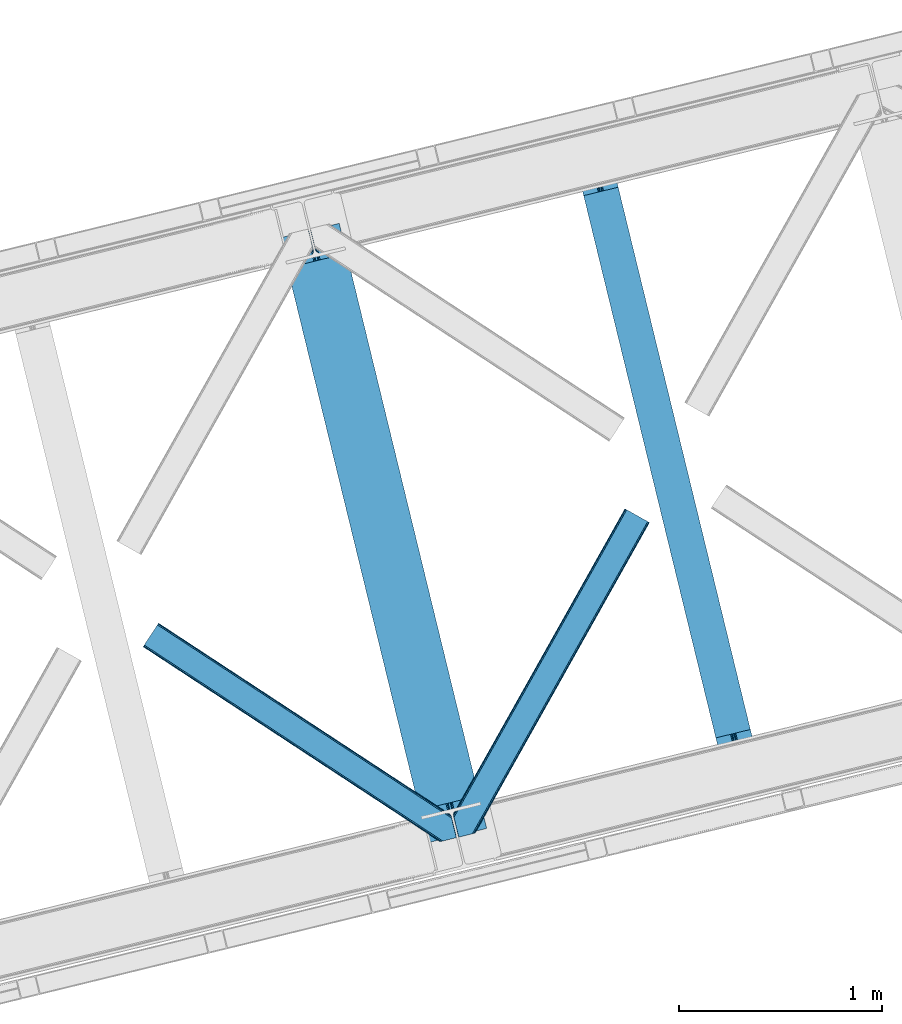
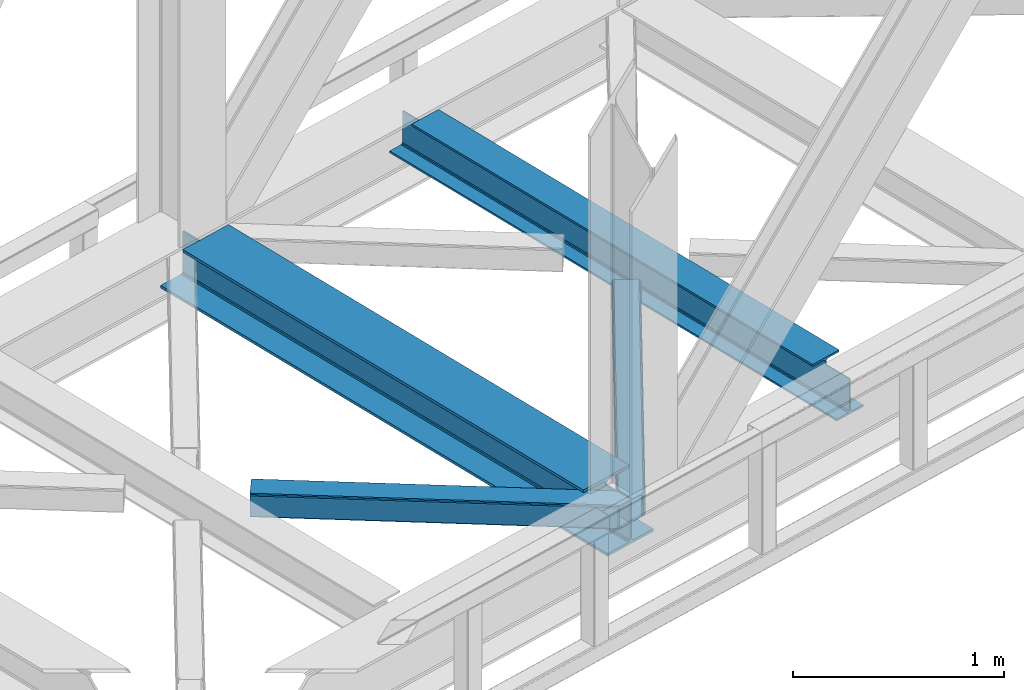
# One storey, part 79 of 92: 2 beams, 2 members.
"""IFC4 building model written with IfcOpenShell, lengths in millimetres."""

from ifc_helpers import new_model, entity, si_unit, converted_unit, derived_unit, direction, frame, origin, place, context, subcontext, project, spatial, triangles, polygons, material, type_object, element, save


model = new_model("IFC4")

# Units and contexts
model_context = context("Model", 3, precision=0.01, world=origin(), true_north=direction((6.12303176911189e-17, 1.0)))
plan_context = context("Plan", 3, precision=0.01, world=origin(), true_north=direction((6.12303176911189e-17, 1.0)))
body_context = subcontext(model_context, "Body", "Model", "MODEL_VIEW")
ifc_project = project(units=[si_unit("LENGTHUNIT", "METRE", prefix="MILLI"), si_unit("AREAUNIT", "SQUARE_METRE"), si_unit("VOLUMEUNIT", "CUBIC_METRE"), converted_unit("PLANEANGLEUNIT", "DEGREE", entity("IfcRatioMeasure", 0.0174532925199433), si_unit("PLANEANGLEUNIT", "RADIAN"), dimensions=[0, 0, 0, 0, 0, 0, 0]), si_unit("MASSUNIT", "GRAM", prefix="KILO"), derived_unit("MASSDENSITYUNIT", [(si_unit("MASSUNIT", "GRAM", prefix="KILO"), 1), (si_unit("LENGTHUNIT", "METRE"), -3)]), derived_unit("MOMENTOFINERTIAUNIT", [(si_unit("LENGTHUNIT", "METRE"), 4)]), si_unit("TIMEUNIT", "SECOND"), si_unit("FREQUENCYUNIT", "HERTZ"), si_unit("THERMODYNAMICTEMPERATUREUNIT", "DEGREE_CELSIUS"), derived_unit("THERMALTRANSMITTANCEUNIT", [(si_unit("MASSUNIT", "GRAM", prefix="KILO"), 1), (si_unit("THERMODYNAMICTEMPERATUREUNIT", "KELVIN"), -1), (si_unit("TIMEUNIT", "SECOND"), -3)]), derived_unit("VOLUMETRICFLOWRATEUNIT", [(si_unit("LENGTHUNIT", "METRE"), 3), (si_unit("TIMEUNIT", "SECOND"), -1)]), derived_unit("MASSFLOWRATEUNIT", [(si_unit("MASSUNIT", "GRAM", prefix="KILO"), 1), (si_unit("TIMEUNIT", "SECOND"), -1)]), derived_unit("ROTATIONALFREQUENCYUNIT", [(si_unit("TIMEUNIT", "SECOND"), -1)]), si_unit("ELECTRICCURRENTUNIT", "AMPERE"), si_unit("ELECTRICVOLTAGEUNIT", "VOLT"), si_unit("POWERUNIT", "WATT"), si_unit("FORCEUNIT", "NEWTON", prefix="KILO"), si_unit("ILLUMINANCEUNIT", "LUX"), si_unit("LUMINOUSFLUXUNIT", "LUMEN"), si_unit("LUMINOUSINTENSITYUNIT", "CANDELA"), derived_unit("USERDEFINED", [(si_unit("MASSUNIT", "GRAM", prefix="KILO"), -1), (si_unit("LENGTHUNIT", "METRE"), -2), (si_unit("TIMEUNIT", "SECOND"), 3), (si_unit("LUMINOUSFLUXUNIT", "LUMEN"), 1)]), derived_unit("LINEARVELOCITYUNIT", [(si_unit("LENGTHUNIT", "METRE"), 1), (si_unit("TIMEUNIT", "SECOND"), -1)]), si_unit("PRESSUREUNIT", "PASCAL"), derived_unit("USERDEFINED", [(si_unit("LENGTHUNIT", "METRE"), -2), (si_unit("MASSUNIT", "GRAM", prefix="KILO"), 1), (si_unit("TIMEUNIT", "SECOND"), -2)]), derived_unit("LINEARFORCEUNIT", [(si_unit("MASSUNIT", "GRAM", prefix="KILO"), 1), (si_unit("LENGTHUNIT", "METRE"), 1), (si_unit("TIMEUNIT", "SECOND"), -2), (si_unit("LENGTHUNIT", "METRE"), -1)]), derived_unit("PLANARFORCEUNIT", [(si_unit("MASSUNIT", "GRAM", prefix="KILO"), 1), (si_unit("LENGTHUNIT", "METRE"), 1), (si_unit("TIMEUNIT", "SECOND"), -2), (si_unit("LENGTHUNIT", "METRE"), -2)])], contexts=[model_context, plan_context])

# Site, building, storey
site_placement = place(None, origin())
site = spatial("IfcSite", under=ifc_project, at=site_placement, CompositionType="ELEMENT")
building_placement = place(site_placement, origin())
building = spatial("IfcBuilding", under=site, at=building_placement, CompositionType="ELEMENT")
storey_placement = place(building_placement, frame((0.0, 0.0, 15900.0)))
storey = spatial("IfcBuildingStorey", under=building, at=storey_placement, Name="05", CompositionType="ELEMENT", Elevation=15900.0)

# Beams
ifc_material = material(Name="Metal painted (White)")
beam_type = type_object("IfcBeamType", PredefinedType="BEAM")
beam_1_placement = place(storey_placement, frame((-9086.33, 15580.04, 3385.0)))
element("IfcBeam", 1, at=beam_1_placement, inside=storey, type_object=beam_type, material=ifc_material, ObjectType="Steel Beam", PredefinedType="BEAM", context=body_context, shape_type="Tessellation", body=[
    polygons([(1018.1664837833, 71.0478278971021, 15.4999999999986), (1018.1664837833, 71.0478278971021, 0.0), (291.465617442452, 3052.25531830421, 0.0), (291.465617442452, 3052.25531830421, 15.4999999999986), (894.779372399334, 40.9709140873313, 15.4999999999986), (168.078506058486, 3022.17840449444, 15.4999999999986), (888.08702862538, 39.3395844888265, 16.8701684147963), (161.386162284532, 3020.54707489594, 16.8701684147963), (882.413533524765, 37.956610033654, 20.7720779386456), (155.712667183913, 3019.16410044077, 20.7720779386456), (878.622625296187, 37.0325360459184, 26.6116982174294), (151.921758955338, 3018.24002645303, 26.6116982174294), (877.291435352789, 36.7080444135029, 33.500000000001), (150.590569011938, 3017.91553482062, 33.500000000001), (140.875048430526, 3015.54727389071, 33.500000000001), (140.875048430525, 3015.54727389071, 259.000000000002), (150.590569011936, 3017.91553482062, 259.000000000002), (0.0, 2981.20749040711, 0.0), (3.24860138789518e-12, 2981.20749040711, 15.4999999999986), (123.387111383965, 3011.28440421689, 15.4999999999986), (130.079455157938, 3012.91573381539, 16.8701684147963), (135.752950258552, 3014.29870827056, 20.7720779386369), (139.543858487129, 3015.2227822583, 26.6116982174294), (877.291435352786, 36.7080444135029, 259.000000000002), (867.575914771374, 34.3397834836014, 259.000000000002), (867.575914771377, 34.3397834836014, 33.500000000001), (866.24472482798, 34.0152918511859, 26.6116982174294), (862.453816599403, 33.0912178634502, 20.7720779386369), (856.780321498787, 31.70824340828, 16.8701684147963), (850.087977724816, 30.0769138097708, 15.4999999999986), (726.700866340855, 0.0, 15.4999999999986), (726.700866340851, 0.0, 0.0), (838.124523615913, 197.385937999181, 259.069791973884), (186.469722099971, 2870.72539801219, 259.000000000002), (186.693115201823, 2869.80895360721, 259.61730333112), (186.70550404545, 2869.75812937344, 266.500003008253), (837.979344808147, 197.981416001704, 266.500002998871), (837.979694928899, 197.979979696973, 260.000004007589), (828.499586345882, 194.645865944434, 259.006343171919), (828.27621632612, 195.562317481914, 259.61730333112), (828.263827482491, 195.613141715687, 266.500003008253), (176.989986719794, 2867.38985508742, 266.500002998871), (176.989636599042, 2867.39129139215, 260.000004007589), (176.844830940702, 2867.98534020594, 259.07612046749), (176.75420151856, 2868.35713708228, 259.000000000002), (839.310832678078, 198.30468544639, 273.388305639783), (843.101109266769, 199.231350618303, 279.227924098777), (848.774180214308, 200.616065081981, 283.129832400619), (855.466371895439, 202.248018612794, 284.500000377228), (978.853400583268, 232.325271667905, 284.500000138971), (978.851730776625, 232.332121736637, 299.999995328161), (687.386308679347, 161.283492472596, 299.999995890962), (687.387978486002, 161.276642403863, 284.500000701776), (810.775007173842, 191.353895458974, 284.500000463519), (817.467494070002, 192.984637925557, 283.129832461069), (823.141405718754, 194.365903570079, 279.227924137322), (826.93294050575, 195.287407219375, 273.388305663684), (175.658498849867, 2867.06658564273, 273.388305639783), (171.868222261169, 2866.13992047082, 279.227924098781), (166.195151313643, 2864.75520600715, 283.129832400619), (159.502959632494, 2863.12325247633, 284.500000377228), (36.1159309446587, 2833.04599942122, 284.500000138971), (36.117600751305, 2833.03914935249, 299.999995328161), (327.583022848581, 2904.08777861653, 299.999995890962), (327.581353041927, 2904.09462868526, 284.500000701776), (204.194324354092, 2874.01737563015, 284.500000463519), (197.50183745795, 2872.38663316357, 283.129832461069), (191.827925809185, 2871.00536751905, 279.227924137318), (188.036391022194, 2870.08386386975, 273.388305663684)], [[[1, 2, 3, 4]], [[5, 1, 4, 6]], [[7, 5, 6, 8]], [[9, 7, 8, 10]], [[11, 9, 10, 12]], [[13, 11, 12, 14]], [[15, 16, 17, 14, 12, 10, 8, 6, 4, 3, 18, 19, 20, 21, 22, 23]], [[13, 24, 25, 26, 27, 28, 29, 30, 31, 32, 2, 1, 5, 7, 9, 11]], [[2, 32, 18, 3]], [[32, 31, 19, 18]], [[31, 30, 20, 19]], [[27, 26, 15, 23]], [[28, 27, 23, 22]], [[29, 28, 22, 21]], [[30, 29, 21, 20]], [[33, 24, 13, 14, 17, 34, 35, 36, 37, 38]], [[25, 39, 40, 41, 42, 43, 44, 16, 15, 26]], [[39, 25, 24, 33]], [[45, 34, 17, 16]], [[41, 40, 38, 37, 46, 47, 48, 49, 50, 51, 52, 53, 54, 55, 56, 57]], [[42, 58, 59, 60, 61, 62, 63, 64, 65, 66, 67, 68, 69, 36, 35, 43]], [[46, 37, 36, 69]], [[47, 46, 69, 68]], [[48, 47, 68, 67]], [[49, 48, 67, 66]], [[50, 49, 66, 65]], [[51, 50, 65, 64]], [[52, 51, 64, 63]], [[53, 52, 63, 62]], [[54, 53, 62, 61]], [[55, 54, 61, 60]], [[56, 55, 60, 59]], [[57, 56, 59, 58]], [[41, 57, 58, 42]]], closed=False),
])
beam_2_placement = place(storey_placement, frame((-7626.58, 15935.87, 3441.0)))
element("IfcBeam", 2, at=beam_2_placement, inside=storey, type_object=beam_type, material=ifc_material, ObjectType="Steel Beam", PredefinedType="BEAM", context=body_context, shape_type="Tessellation", body=[
    polygons([(896.722476515611, 41.4445662733103, 11.000000000004), (896.722476515614, 41.4445662733103, 2.16573425859679e-12), (170.021610174762, 3022.65205668042, 2.16573425859679e-12), (170.02161017476, 3022.65205668042, 11.000000000004), (830.656936561979, 25.3403919499634, 11.000000000004), (103.956070221129, 3006.54788235708, 11.000000000004), (824.708186540692, 23.8903211957374, 12.2179274798217), (98.0073201998416, 3005.09781160285, 12.2179274798217), (819.665079784588, 22.6610105689172, 15.686291501017), (92.9642134437373, 3003.86850097603, 15.686291501017), (816.295383581406, 21.8396114687097, 20.8770650821657), (89.594517240556, 3003.04710187582, 20.8770650821657), (815.112103631725, 21.5511744621184, 27.0000000000047), (88.4112372908755, 3002.75866486923, 27.0000000000047), (81.6103728838779, 3001.1008822183, 27.0000000000047), (81.6103728838768, 3001.1008822183, 203.000000000006), (88.411237290882, 3002.75866486923, 203.000000000006), (3.24860138789518e-12, 2981.20749040711, 2.16573425859679e-12), (3.24860138789518e-12, 2981.20749040711, 10.9999999999997), (66.0655399536161, 2997.31166473045, 11.000000000004), (72.0142899749205, 2998.76173548468, 12.2179274798217), (77.0573967310281, 2999.9910461115, 15.6862915010192), (80.427092934204, 3000.81244521171, 20.8770650821657), (815.112103631733, 21.5511744621227, 203.000000000006), (808.311239224728, 19.8933918111854, 203.000000000006), (808.311239224728, 19.8933918111854, 27.0000000000047), (807.127959275053, 19.6049548045984, 20.8770650821657), (803.758263071879, 18.7835557043887, 15.6862915010192), (798.715156315771, 17.5542450775707, 12.2179274798217), (792.766406294467, 16.1041743233403, 11.000000000004), (726.700866340853, 2.16573425859679e-12, 10.9999999999997), (726.700866340856, 2.16573425859679e-12, 2.16573425859679e-12), (775.945201911976, 182.229070489532, 203.069792164282), (124.290390378929, 2855.5685280608, 203.000000000006), (124.513271168076, 2854.65418562638, 203.617301946336), (124.526185412596, 2854.60120565348, 217.000003693143), (775.799998669246, 182.824605273256, 217.000003676718), (775.800869277144, 182.821033832377, 204.00000679514), (769.2349007589, 180.199471824625, 203.006342981088), (769.012053092174, 181.113823838952, 203.617301946336), (768.999138847647, 181.166803811845, 217.000003693143), (117.725325590999, 2852.94340419207, 217.000003676718), (117.724454983107, 2852.94697563295, 204.00000679514), (117.580155394048, 2853.53894853353, 203.076120467494), (117.489525971923, 2853.91074540987, 203.000000000006), (776.983483393265, 183.112202246694, 223.122939328039), (780.352479801945, 183.936472070573, 228.313710402595), (785.395115205969, 185.167716295879, 231.782072735464), (791.343694076666, 186.618489150559, 232.999999602236), (857.4091449422, 202.723028934495, 232.999999283132), (857.407671605763, 202.729072911368, 243.999994005812), (687.386290701845, 161.28356611448, 243.999994827032), (687.387764038282, 161.277522137607, 233.000000104353), (753.453214903794, 177.382061921539, 232.999999785253), (759.402120032139, 178.831496389766, 231.782072861012), (764.445684539266, 180.058929212901, 228.313710479427), (767.816071449004, 180.87749487033, 223.12293937232), (116.541840866978, 2852.65580721863, 223.122939328039), (113.172844458302, 2851.83153739476, 228.313710402595), (108.130209054283, 2850.60029316945, 231.782072735464), (102.181630183566, 2849.14952031477, 232.999999602236), (36.1161793180469, 2833.04498053083, 232.999999283128), (36.1176526544877, 2833.03893655396, 243.999994005812), (206.139033558404, 2874.48444335085, 243.999994827032), (206.137560221967, 2874.49048732772, 233.000000104357), (140.072109356437, 2858.38594754379, 232.999999785253), (134.123204228111, 2856.93651307557, 231.782072861012), (129.079639720983, 2855.70908025243, 228.313710479427), (125.709252811239, 2854.890514595, 223.12293937232)], [[[1, 2, 3, 4]], [[5, 1, 4, 6]], [[7, 5, 6, 8]], [[9, 7, 8, 10]], [[11, 9, 10, 12]], [[13, 11, 12, 14]], [[15, 16, 17, 14, 12, 10, 8, 6, 4, 3, 18, 19, 20, 21, 22, 23]], [[13, 24, 25, 26, 27, 28, 29, 30, 31, 32, 2, 1, 5, 7, 9, 11]], [[2, 32, 18, 3]], [[32, 31, 19, 18]], [[31, 30, 20, 19]], [[27, 26, 15, 23]], [[28, 27, 23, 22]], [[29, 28, 22, 21]], [[30, 29, 21, 20]], [[33, 24, 13, 14, 17, 34, 35, 36, 37, 38]], [[25, 39, 40, 41, 42, 43, 44, 16, 15, 26]], [[39, 25, 24, 33]], [[45, 34, 17, 16]], [[41, 40, 38, 37, 46, 47, 48, 49, 50, 51, 52, 53, 54, 55, 56, 57]], [[42, 58, 59, 60, 61, 62, 63, 64, 65, 66, 67, 68, 69, 36, 35, 43]], [[46, 37, 36, 69]], [[47, 46, 69, 68]], [[48, 47, 68, 67]], [[49, 48, 67, 66]], [[50, 49, 66, 65]], [[51, 50, 65, 64]], [[52, 51, 64, 63]], [[53, 52, 63, 62]], [[54, 53, 62, 61]], [[55, 54, 61, 60]], [[56, 55, 60, 59]], [[57, 56, 59, 58]], [[41, 57, 58, 42]]], closed=False),
])

# Members
member_type_1 = type_object("IfcMemberType", PredefinedType="BRACE")
member_1_placement = place(storey_placement, frame((-8233.36, 15608.24, 3510.0)))
element("IfcMember", 3, at=member_1_placement, inside=storey, type_object=member_type_1, ObjectType="Steel Horizontal Brace", PredefinedType="BRACE", context=body_context, shape_type="Tessellation", body=[
    triangles([(967.681050109863, 1549.66471252441, 122.500662231447), (966.521237182617, 1550.31699829101, 129.197927856447), (108.493377685547, 19.761584472657, 122.500662231447), (106.721974182128, 19.3302154541016, 129.197927856447), (963.215043640136, 1552.17502441406, 134.874325561526), (101.679258728027, 18.1012207031254, 134.874325561526), (958.263020324707, 1554.95392456055, 138.667117309571), (94.1378585815428, 16.2629608154293, 138.667117309571), (952.422679138183, 1558.23395690918, 139.999594116212), (85.2360763549805, 14.0921630859375, 139.999594116212), (967.681050109863, 1549.66471252441, 17.5000946044929), (108.493377685547, 19.761584472657, 17.5000946044929), (6.07462921142542, 87.5702362060547, 139.999594116212), (27.4210006713856, 0.0, 139.999594116212), (860.874778747559, 1609.64826049805, 139.999594116212), (855.034437561035, 1612.92829284668, 138.667117309571), (3.74977111816406, 97.1068634033199, 138.667117309571), (850.082414245605, 1615.70719299316, 134.874325561526), (1.77896118164063, 105.192416381837, 134.874325561526), (846.776220703125, 1617.56521911621, 129.197927856447), (0.462181091308594, 110.594412231445, 129.197927856447), (845.616407775879, 1618.21750488281, 122.500662231447), (0.0, 112.491970825195, 122.500662231447), (845.616407775879, 1618.21750488281, 17.5000946044929), (0.0, 112.491970825195, 17.5000946044929), (966.521237182617, 1550.31699829101, 10.8028289794929), (106.721974182128, 19.3302154541016, 10.8028289794929), (156.767756652832, 115.413885498047, 5.52059326172093), (963.215043640136, 1552.17502441406, 5.12526855468968), (156.952047729492, 116.778918457032, 5.02062377929906), (102.189692687988, 18.2256317138672, 5.52059326172093), (958.263020324707, 1554.95392456055, 1.33247680664135), (157.131687927245, 118.142788696288, 4.52065429687718), (155.381794738769, 125.321420288086, 1.33247680664135), (952.422679138183, 1558.23395690918, 0.0), (153.056936645507, 134.858047485352, 0.0), (124.438916015624, 252.261346435547, 0.0), (94.4628387451166, 244.953652954102, 0.0), (860.874778747559, 1609.64826049805, 0.0), (77.5132919311518, 240.822509765625, 5.52059326172093), (85.5657073974608, 242.785180664063, 1.33247680664135), (123.842440795898, 252.116006469727, 5.44385375976708), (124.438916015624, 252.261346435547, 4.52065429687718), (846.776220703125, 1617.56521911621, 10.8028289794929), (1.68013000488281, 112.178036499023, 10.9621215820334), (0.251147460936409, 111.460638427734, 12.5201660156272), (850.082414245605, 1615.70719299316, 5.12526855468968), (855.034437561035, 1612.92829284668, 1.33247680664135), (6.66994171142505, 114.682534790039, 5.52059326172093), (34.2211669921871, 1.65687561035156, 5.52059326172093), (123.467463684082, 252.024151611327, 5.52059326172093), (32.7846267700188, 1.30689697265552, 6.99957275390625), (12.4672622680664, 84.6564605712883, 6.99957275390625), (9.18839263916016, 92.4908660888668, 8.3320495605476), (4.07649536132703, 95.7674102783203, 12.5201660156272), (75.9366439819332, 11.8260223388679, 6.99957275390625), (946.321307373047, 1561.66165466309, 6.99957275390625), (866.976150512695, 1606.22056274414, 6.99957275390625), (861.135809326172, 1609.49943237305, 8.3320495605476), (856.187855529784, 1612.28065795899, 12.1260040283232), (852.877592468261, 1614.1375213623, 17.8035644531265), (2.89226531982422, 100.625253295899, 17.8035644531265), (851.717779541015, 1614.78980712891, 24.4996673583992), (2.43008422851563, 102.522811889648, 24.4996673583992), (961.579678344727, 1553.09241027832, 24.4996673583992), (960.415214538574, 1553.7435333252, 17.8035644531265), (99.1892944335932, 17.4942810058601, 24.4996673583992), (97.4178909301754, 17.0617492675774, 17.8035644531265), (957.109602355957, 1555.60155944824, 12.1260040283232), (92.3798263549797, 15.8339172363285, 12.1260040283232), (952.16164855957, 1558.38278503418, 8.3320495605476), (84.8337753295891, 13.994494628907, 8.3320495605476), (961.579678344727, 1553.09241027832, 115.501089477541), (99.1892944335932, 17.4942810058601, 115.501089477541), (84.8337753295891, 13.994494628907, 131.667544555665), (75.9366439819332, 11.8260223388679, 133.000021362306), (27.4210006713856, 0.0, 133.000021362306), (92.3798263549797, 15.8339172363285, 127.87475280762), (97.4178909301754, 17.0617492675774, 122.196029663086), (946.321307373047, 1561.66165466309, 133.000021362306), (952.16164855957, 1558.38278503418, 131.667544555665), (957.109602355957, 1555.60155944824, 127.87475280762), (960.415214538574, 1553.7435333252, 122.196029663086), (856.187855529784, 1612.28065795899, 127.87475280762), (866.976150512695, 1606.22056274414, 133.000021362306), (861.135809326172, 1609.49943237305, 131.667544555665), (851.717779541015, 1614.78980712891, 115.501089477541), (852.877592468261, 1614.1375213623, 122.196029663086), (4.20904541015625, 95.2232574462887, 127.87475280762), (2.89226531982422, 100.625253295899, 122.196029663086), (6.17985534667969, 87.1377044677738, 131.667544555665), (8.50471343994104, 77.6010772705085, 133.000021362306), (2.43008422851563, 102.522811889648, 115.501089477541)], [[1, 2, 3], [4, 3, 2], [2, 5, 4], [6, 4, 5], [5, 7, 6], [8, 6, 7], [7, 9, 8], [10, 8, 9], [11, 1, 3], [3, 12, 11], [13, 10, 9], [10, 13, 14], [9, 15, 13], [15, 16, 17], [17, 13, 15], [16, 18, 19], [19, 17, 16], [18, 20, 21], [21, 19, 18], [20, 22, 23], [23, 21, 20], [22, 24, 25], [25, 23, 22], [26, 27, 28], [28, 29, 26], [28, 30, 29], [27, 31, 28], [30, 32, 29], [30, 33, 32], [33, 34, 32], [35, 32, 36], [34, 36, 32], [26, 11, 12], [12, 27, 26], [37, 38, 39], [36, 37, 35], [39, 35, 37], [38, 40, 41], [38, 37, 42], [38, 42, 40], [42, 37, 43], [43, 36, 33], [36, 43, 37], [34, 33, 36], [24, 44, 45], [45, 46, 24], [47, 48, 41], [45, 44, 40], [44, 47, 40], [40, 49, 45], [41, 40, 47], [48, 39, 38], [38, 41, 48], [46, 25, 24], [31, 49, 28], [31, 50, 49], [40, 28, 49], [51, 28, 40], [50, 52, 53], [49, 53, 54], [53, 49, 50], [55, 45, 49], [49, 54, 55], [46, 45, 55], [53, 56, 57], [56, 53, 52], [57, 58, 53], [59, 60, 55], [60, 61, 62], [62, 55, 60], [61, 63, 64], [64, 62, 61], [58, 59, 54], [54, 53, 58], [55, 54, 59], [65, 66, 67], [68, 67, 66], [66, 69, 68], [70, 68, 69], [69, 71, 70], [72, 70, 71], [71, 57, 72], [56, 72, 57], [73, 65, 67], [67, 74, 73], [8, 10, 75], [14, 76, 10], [76, 14, 77], [76, 75, 10], [78, 8, 75], [78, 6, 8], [6, 79, 4], [79, 6, 78], [3, 79, 74], [79, 3, 4], [56, 31, 72], [68, 70, 31], [70, 72, 31], [56, 50, 31], [50, 56, 52], [67, 68, 12], [27, 12, 68], [3, 67, 12], [67, 3, 74], [68, 31, 27], [80, 81, 75], [75, 76, 80], [81, 82, 78], [78, 75, 81], [82, 83, 79], [79, 78, 82], [83, 73, 74], [74, 79, 83], [26, 69, 66], [65, 1, 11], [26, 66, 11], [26, 29, 69], [66, 65, 11], [69, 29, 32], [57, 35, 39], [35, 71, 32], [71, 35, 57], [71, 69, 32], [2, 82, 5], [73, 1, 65], [1, 83, 2], [83, 1, 73], [2, 83, 82], [9, 80, 15], [7, 5, 82], [82, 81, 7], [81, 80, 9], [9, 7, 81], [60, 48, 47], [39, 58, 57], [39, 59, 58], [59, 39, 48], [60, 59, 48], [63, 24, 22], [44, 61, 60], [47, 44, 60], [61, 44, 24], [63, 61, 24], [16, 84, 18], [15, 80, 85], [85, 86, 15], [86, 84, 16], [16, 15, 86], [20, 18, 84], [22, 87, 63], [88, 22, 20], [22, 88, 87], [88, 20, 84], [89, 19, 90], [91, 92, 13], [92, 14, 13], [92, 77, 14], [17, 91, 13], [89, 17, 19], [89, 91, 17], [23, 64, 93], [21, 90, 19], [93, 90, 23], [90, 21, 23], [25, 64, 23], [46, 55, 62], [62, 64, 25], [25, 46, 62], [76, 92, 80], [76, 77, 92], [85, 80, 92], [63, 87, 93], [93, 64, 63], [87, 88, 93], [90, 93, 88], [88, 84, 90], [89, 90, 84], [84, 86, 89], [91, 89, 86], [86, 85, 91], [92, 91, 85]]),
])
member_type_2 = type_object("IfcMemberType", PredefinedType="BRACE")
member_2_placement = place(storey_placement, frame((-9761.38, 15585.64, 3510.0)))
element("IfcMember", 4, at=member_2_placement, inside=storey, type_object=member_type_2, ObjectType="Steel Horizontal Brace", PredefinedType="BRACE", context=body_context, shape_type="Tessellation", body=[
    triangles([(1516.36209411621, 132.252392578124, 122.500662231447), (1516.36209411621, 132.252392578124, 17.5000946044929), (76.8296127319336, 1077.23657226563, 17.5000946044929), (76.8296127319336, 1077.23657226563, 122.500662231447), (1516.82427520752, 130.355996704102, 129.197927856447), (76.0959365844719, 1076.12152404785, 129.197927856447), (1518.14163665771, 124.954000854492, 134.874325561526), (74.0158309936523, 1072.95078735351, 134.874325561526), (1520.11244659424, 116.868447875977, 138.667117309571), (70.9026489257813, 1068.20572814941, 138.667117309571), (1522.43672332764, 107.331820678712, 139.999594116212), (67.226129150391, 1062.60723266601, 139.999594116212), (9.60290222167896, 974.828869628906, 139.999594116212), (1485.968019104, 5.66825866699219, 139.999594116212), (1543.7830947876, 19.761584472657, 139.999594116212), (1477.07088775635, 3.49978637695313, 138.667117309571), (5.92754516601599, 969.230374145507, 138.667117309571), (1469.52483673096, 1.66036376953161, 134.874325561526), (2.81378173828125, 964.485314941405, 134.874325561526), (1464.48677215576, 0.431369018555415, 129.197927856447), (0.733676147459846, 961.314578247071, 129.197927856447), (1462.71536865234, 0.0, 122.500662231447), (0.0, 960.199530029298, 122.500662231447), (1462.71536865234, 0.0, 17.5000946044929), (0.0, 960.199530029298, 17.5000946044929), (1516.61324157715, 131.222222900391, 12.5201660156272), (1515.01450195312, 131.20245666504, 10.9621215820334), (76.0959365844719, 1076.12152404785, 10.8028289794929), (1387.90133056641, 210.375531005859, 5.21247253418187), (74.0158309936523, 1072.95078735351, 5.12526855468968), (1509.43170318604, 131.129205322266, 5.52059326172093), (1380.44073944092, 208.557037353516, 1.33247680664135), (1371.53953857422, 206.387402343749, 0.0), (70.9026489257813, 1068.20572814941, 1.33247680664135), (67.226129150391, 1062.60723266601, 0.0), (1375.83462524414, 62.7066375732429, 5.51129150390625), (1387.90074920654, 210.375531005859, 5.38222961426072), (1509.43170318604, 131.129205322266, 5.43687744140698), (1342.53433227539, 199.316903686524, 5.39734497070458), (1469.0190536499, 1.53711547851526, 5.55431213379052), (1536.9829284668, 18.1035461425781, 5.53222045898656), (0.733676147459846, 961.314578247071, 10.8028289794929), (2.81378173828125, 964.485314941405, 5.12526855468968), (1375.04746398926, 63.8344757080085, 5.02062377929906), (5.92754516601599, 969.230374145507, 1.33247680664135), (1372.50575866699, 72.139782714843, 1.33247680664135), (1374.25565185547, 64.9611511230469, 4.52065429687718), (1370.18148193359, 81.6775726318356, 0.0), (9.60290222167896, 974.828869628906, 0.0), (1464.48677215576, 0.431369018555415, 10.8028289794929), (1469.0190536499, 1.53711547851526, 5.52059326172093), (1375.83462524414, 62.7066375732429, 5.52059326172093), (1341.56287994385, 199.079708862304, 0.0), (1342.53433227539, 199.316903686524, 5.52059326172093), (1341.56287994385, 199.079708862304, 4.52065429687718), (1520.43858947754, 115.528994750977, 12.5201660156272), (1517.41261138916, 110.268850708007, 8.3320495605476), (1538.41946868896, 18.4535247802742, 6.99957275390625), (1536.9829284668, 18.1035461425781, 5.52059326172093), (1518.10210418701, 101.803088378907, 6.99957275390625), (13.4468536376953, 980.68200073242, 6.99957275390625), (63.3821777343746, 1056.7541015625, 6.99957275390625), (1495.27152099609, 7.93556213378906, 6.99957275390625), (67.0586975097649, 1062.3525970459, 8.3320495605476), (70.1765304565433, 1067.09998168945, 12.1260040283232), (1519.25435943603, 120.386837768554, 17.8035644531265), (1518.79217834473, 122.284396362305, 24.4996673583992), (72.2566360473629, 1070.27071838379, 17.8035644531265), (72.9856613159172, 1071.38344116211, 24.4996673583992), (1518.79217834473, 122.284396362305, 115.501089477541), (72.9856613159172, 1071.38344116211, 115.501089477541), (1520.57113952637, 114.984841918946, 127.87475280762), (1519.25435943603, 120.386837768554, 122.196029663086), (1524.86680755615, 97.3626617431637, 133.000021362306), (1522.54194946289, 106.899288940429, 131.667544555665), (1543.7830947876, 19.761584472657, 133.000021362306), (63.3821777343746, 1056.7541015625, 133.000021362306), (67.0586975097649, 1062.3525970459, 131.667544555665), (70.1765304565433, 1067.09998168945, 127.87475280762), (72.2566360473629, 1070.27071838379, 122.196029663086), (13.4468536376953, 980.68200073242, 133.000021362306), (1495.27152099609, 7.93556213378906, 133.000021362306), (6.65308227539026, 970.336120605469, 12.1260040283232), (9.77091522216688, 975.083505249022, 8.3320495605476), (3.84395141601453, 966.052661132813, 24.4996673583992), (4.57297668457068, 967.165383911131, 17.8035644531265), (6.65308227539026, 970.336120605469, 127.87475280762), (9.77091522216688, 975.083505249022, 131.667544555665), (3.84395141601453, 966.052661132813, 115.501089477541), (4.57297668457068, 967.165383911131, 122.196029663086), (1478.82891998291, 3.92766723632849, 127.87475280762), (1486.37438964844, 5.76708984375, 131.667544555665), (1473.78620452881, 2.69867248535229, 122.196029663086), (1472.0194519043, 2.26846618652417, 115.501089477541), (1472.0194519043, 2.26846618652417, 24.4996673583992), (1478.82891998291, 3.92766723632849, 12.1260040283232), (1473.78620452881, 2.69867248535229, 17.8035644531265), (1486.37438964844, 5.76708984375, 8.3320495605476)], [[1, 2, 3], [3, 4, 1], [5, 1, 6], [4, 6, 1], [7, 5, 8], [6, 8, 5], [9, 7, 10], [8, 10, 7], [11, 9, 12], [10, 12, 9], [13, 11, 12], [11, 13, 14], [15, 11, 14], [16, 14, 13], [13, 17, 16], [18, 16, 17], [17, 19, 18], [20, 18, 19], [19, 21, 20], [22, 20, 21], [21, 23, 22], [24, 22, 25], [23, 25, 22], [3, 26, 27], [3, 2, 26], [28, 27, 29], [29, 30, 28], [27, 31, 29], [30, 29, 32], [32, 33, 34], [35, 34, 33], [32, 34, 30], [27, 28, 3], [36, 37, 38], [37, 36, 39], [38, 40, 36], [41, 40, 38], [42, 43, 44], [43, 45, 46], [46, 47, 43], [47, 44, 43], [48, 46, 45], [45, 49, 48], [50, 24, 42], [25, 42, 24], [51, 50, 52], [42, 52, 50], [53, 35, 33], [49, 53, 48], [53, 49, 35], [33, 54, 53], [29, 33, 32], [53, 54, 55], [29, 54, 33], [48, 55, 47], [48, 53, 55], [47, 46, 48], [56, 31, 27], [57, 31, 56], [27, 26, 56], [58, 59, 60], [60, 31, 57], [31, 60, 59], [61, 60, 62], [60, 61, 63], [58, 60, 63], [64, 57, 56], [65, 56, 66], [66, 67, 68], [69, 68, 67], [66, 68, 65], [56, 65, 64], [60, 57, 62], [64, 62, 57], [67, 70, 71], [71, 69, 67], [72, 7, 9], [7, 72, 73], [74, 75, 11], [75, 72, 9], [76, 74, 15], [11, 15, 74], [75, 9, 11], [26, 66, 56], [2, 1, 67], [67, 66, 2], [26, 2, 66], [1, 70, 67], [73, 5, 7], [1, 5, 73], [70, 1, 73], [75, 74, 77], [77, 78, 75], [72, 75, 78], [78, 79, 72], [73, 72, 79], [79, 80, 73], [70, 73, 80], [80, 71, 70], [81, 74, 82], [81, 77, 74], [74, 76, 82], [28, 65, 68], [69, 4, 3], [28, 68, 3], [28, 30, 65], [68, 69, 3], [65, 30, 34], [62, 35, 49], [35, 64, 34], [64, 35, 62], [64, 65, 34], [6, 79, 8], [71, 4, 69], [4, 80, 6], [80, 4, 71], [6, 80, 79], [12, 77, 13], [10, 8, 79], [79, 78, 10], [78, 77, 12], [12, 10, 78], [83, 45, 43], [49, 61, 62], [49, 84, 61], [84, 49, 45], [83, 84, 45], [85, 25, 23], [42, 86, 83], [43, 42, 83], [86, 42, 25], [85, 86, 25], [17, 87, 19], [13, 77, 81], [81, 88, 13], [88, 87, 17], [17, 13, 88], [21, 19, 87], [23, 89, 85], [90, 23, 21], [23, 90, 89], [90, 21, 87], [91, 92, 16], [18, 91, 16], [93, 18, 20], [93, 22, 94], [18, 93, 91], [22, 93, 20], [92, 14, 16], [15, 82, 76], [15, 14, 82], [92, 82, 14], [22, 95, 94], [51, 96, 97], [97, 95, 24], [24, 95, 22], [97, 50, 51], [50, 97, 24], [59, 63, 51], [63, 98, 51], [98, 96, 51], [59, 58, 63], [93, 94, 90], [89, 90, 94], [91, 93, 87], [90, 87, 93], [92, 91, 88], [87, 88, 91], [82, 92, 81], [88, 81, 92], [94, 95, 85], [85, 89, 94], [98, 63, 61], [61, 84, 98], [96, 98, 84], [84, 83, 96], [97, 96, 83], [83, 86, 97], [95, 97, 86], [86, 85, 95]]),
])

save(model, "model.ifc")
